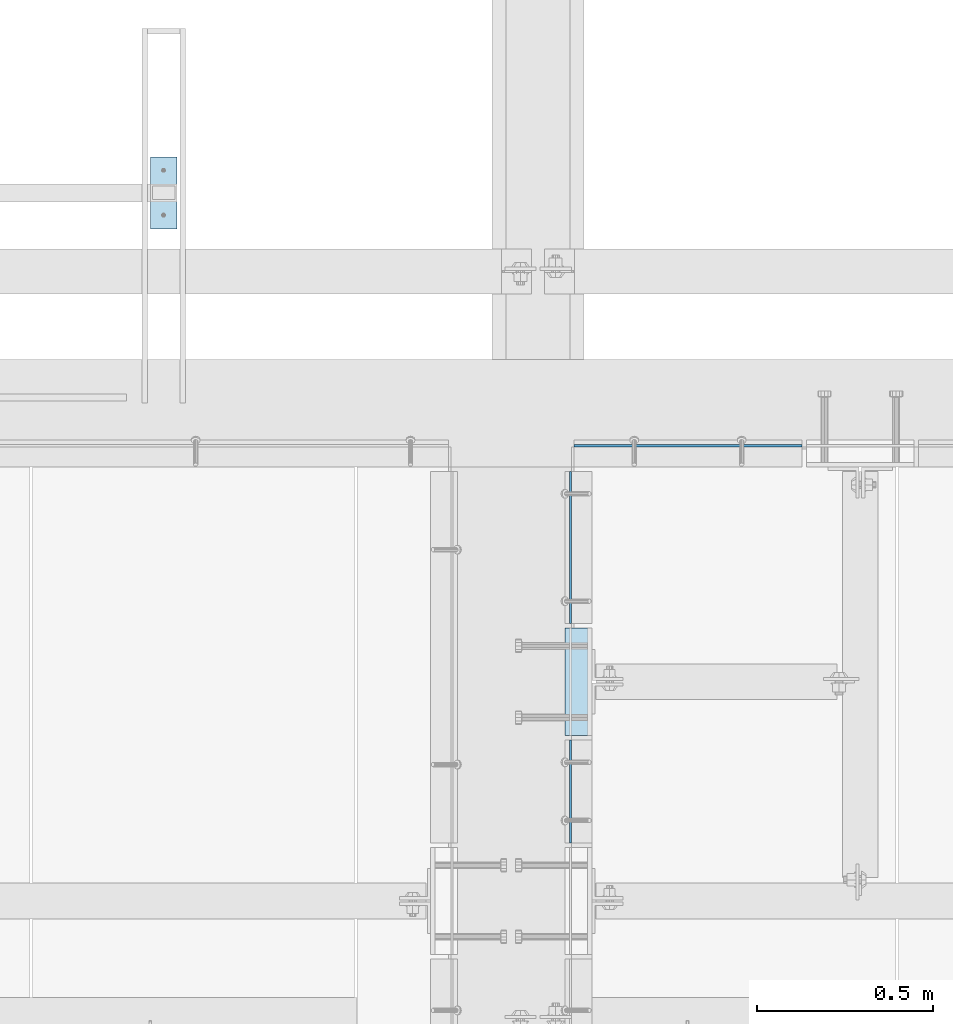
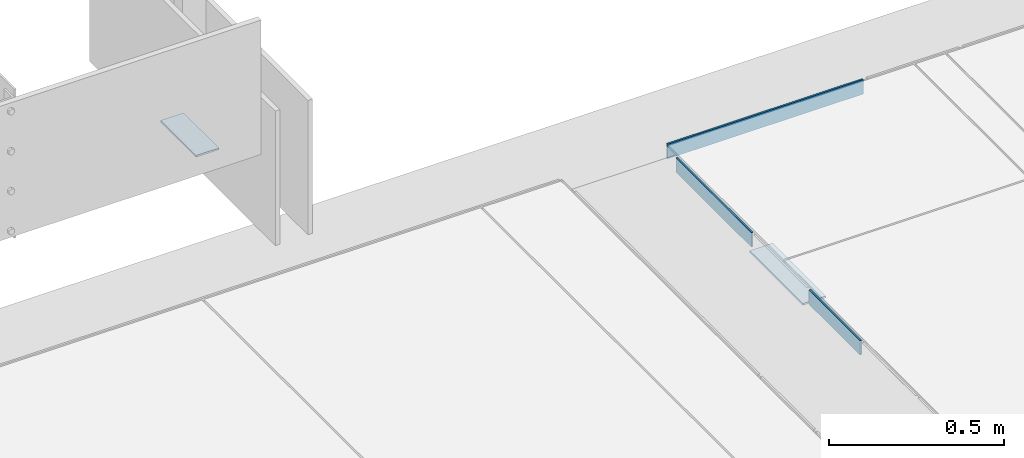
# One storey, part 3168 of 3843: 5 plates, 5 elements without a shape of their own.
"""IFC2X3 building model written with IfcOpenShell, lengths in millimetres."""

from ifc_helpers import new_model, si_unit, frame, origin_with_axes, place, context, subcontext, project, spatial, faceted_brep, material, type_object, element, aggregate, save


model = new_model("IFC2X3")

# Units and contexts
model_context = context("Model", 3, precision=1e-05, world=origin_with_axes())
body_context = subcontext(model_context, "Body", "Model", "MODEL_VIEW")
ifc_project = project(units=[si_unit("LENGTHUNIT", "METRE", prefix="MILLI"), si_unit("AREAUNIT", "SQUARE_METRE"), si_unit("VOLUMEUNIT", "CUBIC_METRE"), si_unit("MASSUNIT", "GRAM", prefix="KILO"), si_unit("TIMEUNIT", "SECOND"), si_unit("PLANEANGLEUNIT", "RADIAN"), si_unit("SOLIDANGLEUNIT", "STERADIAN"), si_unit("THERMODYNAMICTEMPERATUREUNIT", "DEGREE_CELSIUS"), si_unit("LUMINOUSINTENSITYUNIT", "LUMEN")], contexts=[model_context])

# Site, building, storey
site_placement = place(None, origin_with_axes())
site = spatial("IfcSite", under=ifc_project, at=site_placement, CompositionType="ELEMENT")
building_placement = place(site_placement, origin_with_axes())
building = spatial("IfcBuilding", under=site, at=building_placement, Name="Undefined", CompositionType="ELEMENT")
storey_placement = place(building_placement, origin_with_axes())
storey = spatial("IfcBuildingStorey", under=building, at=storey_placement, Name="Undefined", CompositionType="ELEMENT", Elevation=0.0)

# Assembly, plate
assembly_1_placement = place(storey_placement, origin_with_axes())
assembly_1 = element("IfcElementAssembly", 1, at=assembly_1_placement, inside=storey, Name="FRAME", AssemblyPlace="NOTDEFINED", PredefinedType="RIGID_FRAME")
ifc_material_1 = material(Name="STEEL/A572-50")
plate_type_1 = type_object("IfcPlateType", PredefinedType="NOTDEFINED")
plate_1_placement = place(assembly_1_placement, frame((61536.2450197567, 19570.25786883, 30483.175), z_axis=(1.0, 0.0, 0.0), x_axis=(0.0, -1.0, 0.0)))
plate_1 = element("IfcPlate", 2, at=plate_1_placement, type_object=plate_type_1, material=ifc_material_1, Name="PLATE", context=body_context, shape_type="Brep", body=[
    faceted_brep([(0.0, -3.17499999999927, 0.0), (0.0, -3.17499999999927, 76.1999969482422), (0.0, 3.17499999999927, 76.1999969482422), (0.0, 3.17499999999927, 0.0), (203.199996948242, -3.17499999999927, 76.1999969482422), (203.199996948242, 3.17499999999927, 76.1999969482422), (203.199996948242, -3.17499999999927, 0.0), (203.199996948242, 3.17499999999927, 0.0)], [[[0, 1, 2, 3]], [[1, 4, 5, 2]], [[4, 6, 7, 5]], [[6, 0, 3, 7]], [[5, 7, 3, 2]], [[6, 4, 1, 0]]]),
])
aggregate(assembly_1, [plate_1])

assembly_2_placement = place(storey_placement, origin_with_axes())
assembly_2 = element("IfcElementAssembly", 3, at=assembly_2_placement, inside=storey, Name="EMBED PLATE", AssemblyPlace="NOTDEFINED", PredefinedType="RIGID_FRAME")
ifc_material_2 = material(Name="STEEL/A36")
plate_2_placement = place(assembly_2_placement, frame((62788.8000030518, 18234.025, 30426.025), z_axis=(0.0, -1.0, 0.0), x_axis=(-1.0, 0.0, 0.0)))
plate_2 = element("IfcPlate", 4, at=plate_2_placement, type_object=plate_type_1, material=ifc_material_2, Name="PLATE", context=body_context, shape_type="Brep", body=[
    faceted_brep([(0.0, -3.17499999999927, 0.0), (0.0, -3.17499999999927, 304.800000000003), (0.0, 3.17499999999927, 304.800000000003), (0.0, 3.17499999999927, 0.0), (76.1999999999971, -3.17499999999927, 304.799999999996), (76.1999999999971, 3.17499999999927, 304.799999999996), (76.1999999999971, -3.17499999999927, 0.0), (76.1999999999971, 3.17499999999927, 0.0)], [[[0, 1, 2, 3]], [[1, 4, 5, 2]], [[4, 6, 7, 5]], [[6, 0, 3, 7]], [[5, 7, 3, 2]], [[6, 4, 1, 0]]]),
])
aggregate(assembly_2, [plate_2])

assembly_3_placement = place(storey_placement, origin_with_axes())
assembly_3 = element("IfcElementAssembly", 5, at=assembly_3_placement, inside=storey, Name="ANGLE", AssemblyPlace="NOTDEFINED", PredefinedType="RIGID_FRAME")
plate_type_2 = type_object("IfcPlateType", PredefinedType="NOTDEFINED")
plate_3_placement = place(assembly_3_placement, frame((62728.474999136, 17624.4249710295, 30429.2000030518), z_axis=(0.0, 0.999999999997942, -2.02899998962774e-06), x_axis=(0.0, 2.02899999567308e-06, 0.999999999997942)))
plate_3 = element("IfcPlate", 6, at=plate_3_placement, type_object=plate_type_2, material=ifc_material_2, Name="PLATE", context=body_context, shape_type="Brep", body=[
    faceted_brep([(0.0, -3.17499999999927, 0.0), (0.000588252398301847, -3.1750000006723, 292.099914550316), (0.000588252398301847, 3.17499999932625, 292.099914550308), (0.0, 3.17499999999927, 0.0), (50.8005867007196, -3.1750000006723, 292.099853515097), (50.8005867007196, 3.17499999932625, 292.09985351509), (50.7999954217848, -3.17499999999563, -7.27595761418343e-12), (50.7999954217848, 3.17500000001019, -1.09139364212751e-11)], [[[0, 1, 2, 3]], [[1, 4, 5, 2]], [[4, 6, 7, 5]], [[6, 0, 3, 7]], [[5, 7, 3, 2]], [[6, 4, 1, 0]]]),
])
aggregate(assembly_3, [plate_3])

assembly_4_placement = place(storey_placement, origin_with_axes())
assembly_4 = element("IfcElementAssembly", 7, at=assembly_4_placement, inside=storey, Name="ANGLE", AssemblyPlace="NOTDEFINED", PredefinedType="RIGID_FRAME")
plate_4_placement = place(assembly_4_placement, frame((62728.474999136, 18246.7248982287, 30429.2000030518), z_axis=(0.0, 0.999999999997942, -2.02899998962774e-06), x_axis=(0.0, 2.02899999567308e-06, 0.999999999997942)))
plate_4 = element("IfcPlate", 8, at=plate_4_placement, type_object=plate_type_2, material=ifc_material_2, Name="PLATE", context=body_context, shape_type="Brep", body=[
    faceted_brep([(0.0, -3.17499999999927, 0.0), (0.000869328927365132, -3.17499999962456, 431.799987792274), (0.000869328927365132, 3.17500000038126, 431.79998779227), (0.0, 3.17499999999927, 0.0), (50.8008689884919, -3.17499999962456, 431.799926757056), (50.8008689884919, 3.17500000038126, 431.799926757052), (50.7999954217848, -3.17499999999563, -7.27595761418343e-12), (50.7999954217848, 3.17500000001019, -1.09139364212751e-11)], [[[0, 1, 2, 3]], [[1, 4, 5, 2]], [[4, 6, 7, 5]], [[6, 0, 3, 7]], [[5, 7, 3, 2]], [[6, 4, 1, 0]]]),
])
aggregate(assembly_4, [plate_4])

assembly_5_placement = place(storey_placement, origin_with_axes())
assembly_5 = element("IfcElementAssembly", 9, at=assembly_5_placement, inside=storey, Name="ANGLE", AssemblyPlace="NOTDEFINED", PredefinedType="RIGID_FRAME")
plate_5_placement = place(assembly_5_placement, frame((62737.9998695141, 18751.5499009176, 30429.2000030518), z_axis=(1.0, 0.0, 0.0), x_axis=(0.0, 0.0, 1.0)))
plate_5 = element("IfcPlate", 10, at=plate_5_placement, type_object=plate_type_2, material=ifc_material_2, Name="PLATE", context=body_context, shape_type="Brep", body=[
    faceted_brep([(0.0, -3.17499999999927, 0.0), (-1.9818249711534e-05, -3.17499999999927, 647.700134277329), (-1.9818249711534e-05, 3.17499999999927, 647.700134277329), (0.0, 3.17499999999927, 0.0), (50.7999839784352, -3.17499999999927, 647.700134277315), (50.7999839784352, 3.17499999999927, 647.700134277315), (50.7999954217848, -3.17499999999563, -7.27595761418343e-12), (50.7999954217848, 3.17500000001019, -1.09139364212751e-11)], [[[0, 1, 2, 3]], [[1, 4, 5, 2]], [[4, 6, 7, 5]], [[6, 0, 3, 7]], [[5, 7, 3, 2]], [[6, 4, 1, 0]]]),
])
aggregate(assembly_5, [plate_5])

save(model, "model.ifc")
